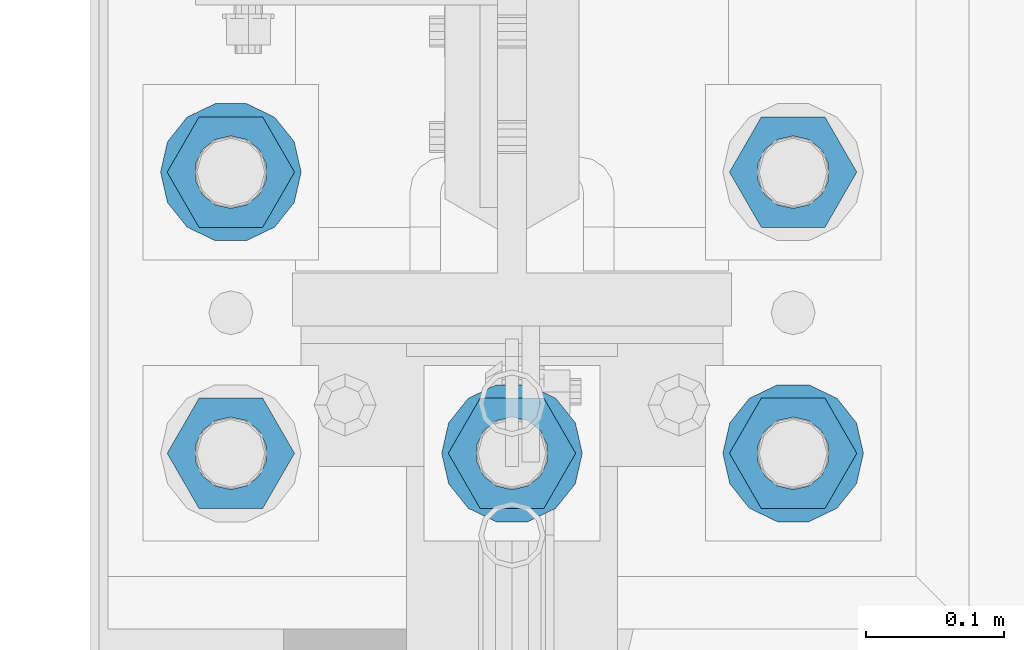
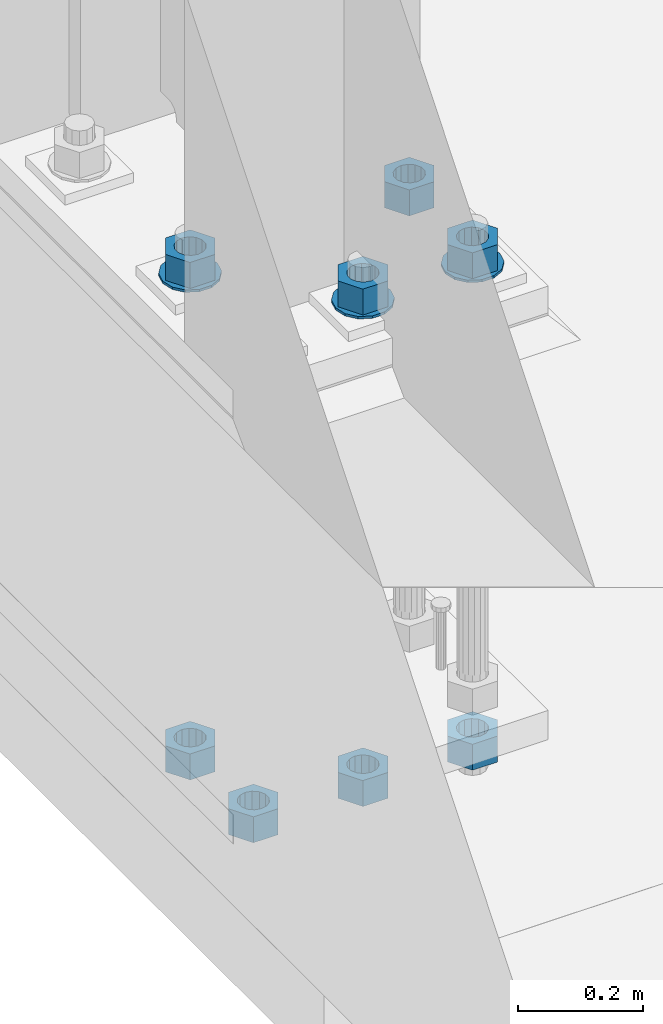
# One storey, part 846 of 1876: 11 columns, 1 element without a shape of its own.
"""IFC2X3 building model written with IfcOpenShell, lengths in millimetres."""

import ifcopenshell
import ifcopenshell.guid

model = None  # the IFC model being written
_history = None  # IfcOwnerHistory: only IFC2X3 demands one
_inside = {}  # id of a spatial element -> (the spatial element, [elements in it])
_under = {}  # id of a project, library or spatial element -> (it, [spatial elements below it])
_declared = {}  # id of a project -> (the project, [libraries it declares])
_typed = {}  # id of a type object -> (the type object, [elements of that type])
_made_of = {}  # id of a material, layer set ... -> (it, [elements and type objects made of it])


def new_model(schema):
    """Start an empty IFC model of exactly this schema.

    Asked for "IFC4X3", IfcOpenShell would pick the latest addendum, in which some entities
    have other attributes; the version numbers below select the first issue.
    IFC2X3 requires an IfcOwnerHistory on every rooted entity: one is made here for all.
    """
    global model, _history
    if schema == "IFC4X3":
        model = ifcopenshell.file(schema_version=(4, 3, 0, 0))
    else:
        model = ifcopenshell.file(schema=schema)
    _inside.clear()
    _under.clear()
    _declared.clear()
    _typed.clear()
    _made_of.clear()
    _history = None
    if model.schema == "IFC2X3":
        org = make("IfcOrganization", Name="unknown")
        user = make(
            "IfcPersonAndOrganization",
            ThePerson=make("IfcPerson", FamilyName="unknown"),
            TheOrganization=org,
        )
        app = make(
            "IfcApplication",
            ApplicationDeveloper=org,
            Version="unknown",
            ApplicationFullName="unknown",
            ApplicationIdentifier="unknown",
        )
        _history = make(
            "IfcOwnerHistory",
            OwningUser=user,
            OwningApplication=app,
            ChangeAction="ADDED",
            CreationDate=0,
        )
    return model


def make(cls, **values):
    """One entity of the class cls with the attributes given. An attribute that is None is left unset."""
    return model.create_entity(
        cls, **{name: value for name, value in values.items() if value is not None}
    )


def rooted(cls, **values):
    """An entity with a GlobalId (a new one), such as an element, a storey or a relation."""
    return make(cls, GlobalId=ifcopenshell.guid.new(), OwnerHistory=_history, **values)


def si_unit(unit_type, name, prefix=None):
    """IfcSIUnit, for example si_unit("LENGTHUNIT", "METRE", prefix="MILLI")."""
    return make("IfcSIUnit", UnitType=unit_type, Prefix=prefix, Name=name)


def assignment(units):
    """IfcUnitAssignment: the units of a project."""
    return None if units is None else make("IfcUnitAssignment", Units=units)


def point(xyz):
    """IfcCartesianPoint."""
    return None if xyz is None else make("IfcCartesianPoint", Coordinates=xyz)


def direction(xyz):
    """IfcDirection."""
    return None if xyz is None else make("IfcDirection", DirectionRatios=xyz)


def frame(location, z_axis=None, x_axis=None):
    """IfcAxis2Placement3D, a coordinate frame: its origin and axes. An axis left out is left unset."""
    return make(
        "IfcAxis2Placement3D",
        Location=point(location),
        Axis=direction(z_axis),
        RefDirection=direction(x_axis),
    )


def origin_with_axes():
    """The frame at (0, 0, 0) with the z axis (0, 0, 1) and the x axis (1, 0, 0) written out."""
    return frame((0.0, 0.0, 0.0), z_axis=(0.0, 0.0, 1.0), x_axis=(1.0, 0.0, 0.0))


def place(relative_to, where):
    """IfcLocalPlacement: puts the frame where relative to a parent placement (None: the world)."""
    return make(
        "IfcLocalPlacement", PlacementRelTo=relative_to, RelativePlacement=where
    )


def context(
    kind, dimensions, precision=None, world=None, true_north=None, identifier=None
):
    """IfcGeometricRepresentationContext, for example the 3D "Model" context."""
    return make(
        "IfcGeometricRepresentationContext",
        ContextIdentifier=identifier,
        ContextType=kind,
        CoordinateSpaceDimension=dimensions,
        Precision=precision,
        WorldCoordinateSystem=world,
        TrueNorth=true_north,
    )


def subcontext(parent, identifier, kind, view, scale=None):
    """IfcGeometricRepresentationSubContext, for example "Body" below "Model"."""
    return make(
        "IfcGeometricRepresentationSubContext",
        ContextIdentifier=identifier,
        ContextType=kind,
        ParentContext=parent,
        TargetScale=scale,
        TargetView=view,
    )


def project(units=None, contexts=None):
    """IfcProject with its units and contexts."""
    return rooted(
        "IfcProject",
        Name="project",
        RepresentationContexts=contexts,
        UnitsInContext=assignment(units),
    )


def spatial(cls, under=None, at=None, **own):
    """A site, building, storey or space (cls), placed at a placement, below another one or the project."""
    s = rooted(cls, ObjectPlacement=at, **own)
    if under is not None:
        _under.setdefault(under.id(), (under, []))[1].append(s)
    return s


def faces_of(points, faces, orient=None, outer=None):
    """IfcFace entities. A face is a list of loops; a loop is a list of indices into points, from 0.

    orient and outer hold one flag for each loop. By default every Orientation is true, the
    first loop of a face is its IfcFaceOuterBound and the others are IfcFaceBound.
    """
    made = []
    for i, loops in enumerate(faces):
        bounds = []
        for j, loop in enumerate(loops):
            is_outer = j == 0 if outer is None else outer[i][j]
            bounds.append(
                make(
                    "IfcFaceOuterBound" if is_outer else "IfcFaceBound",
                    Bound=make("IfcPolyLoop", Polygon=[points[k] for k in loop]),
                    Orientation=True if orient is None else orient[i][j],
                )
            )
        made.append(make("IfcFace", Bounds=bounds))
    return made


def faceted_brep(points, faces, orient=None, outer=None, voids=None):
    """IfcFacetedBrep: a solid bounded by flat faces; with voids (closed shells), ...WithVoids."""
    shared = [point(p) for p in points]
    hull = make("IfcClosedShell", CfsFaces=faces_of(shared, faces, orient, outer))
    if voids is None:
        return make("IfcFacetedBrep", Outer=hull)
    return make(
        "IfcFacetedBrepWithVoids",
        Outer=hull,
        Voids=[
            make(cls, CfsFaces=faces_of(shared, fs, o, b)) for cls, fs, o, b in voids
        ],
    )


def shape(context_of_items, identifier, shape_type, items):
    """IfcShapeRepresentation: the items that make up one representation, for example the "Body"."""
    return make(
        "IfcShapeRepresentation",
        ContextOfItems=context_of_items,
        RepresentationIdentifier=identifier,
        RepresentationType=shape_type,
        Items=items,
    )


def material(Name=None, Category=None):
    """IfcMaterial."""
    return make("IfcMaterial", Name=Name, Category=Category)


def made_of(thing, what):
    """Note that an element or type object is made of a material, layer set ...; save() writes the relation."""
    if what is not None:
        _made_of.setdefault(what.id(), (what, []))[1].append(thing)
    return thing


def type_object(cls, material=None, **own):
    """A type object (cls), such as IfcWallType, which elements share."""
    return made_of(rooted(cls, **own), material)


def element(
    cls,
    number,
    at=None,
    inside=None,
    cuts=None,
    type_object=None,
    material=None,
    context=None,
    identifier="Body",
    shape_type=None,
    held_by="IfcProductDefinitionShape",
    body=None,
    shapes=None,
    **own,
):
    """One element of the class cls, such as IfcWall. Its Tag is "e" and its number.

    at: its placement. inside: the storey or other place that contains it. cuts: it is an
    opening in that element (IfcRelVoidsElement). A single representation is given by context,
    identifier, shape_type and body (its items); several are given by shapes. held_by: the class
    of the entity that holds the representations. save() writes the other relations.
    """
    e = rooted(cls, Tag="e%d" % number, ObjectPlacement=at, **own)
    if body is not None:
        shapes = [shape(context, identifier, shape_type, body)]
    if shapes is not None:
        e.Representation = make(held_by, Representations=shapes)
    if inside is not None:
        _inside.setdefault(inside.id(), (inside, []))[1].append(e)
    if cuts is not None:
        rooted(
            "IfcRelVoidsElement", RelatingBuildingElement=cuts, RelatedOpeningElement=e
        )
    if type_object is not None:
        _typed.setdefault(type_object.id(), (type_object, []))[1].append(e)
    return made_of(e, material)


def aggregate(whole, parts):
    """IfcRelAggregates: a whole, such as a stair, and the parts it consists of."""
    return rooted("IfcRelAggregates", RelatingObject=whole, RelatedObjects=parts)


def save(model, path):
    """Write the relations noted so far, then the file.

    IfcRelAggregates (storeys below a building ...), IfcRelContainedInSpatialStructure (elements
    in a storey), IfcRelDefinesByType, IfcRelAssociatesMaterial and IfcRelDeclares: one each for
    every whole, place, type object, material and project.
    """
    for whole, parts in _under.values():
        aggregate(whole, parts)
    for where, things in _inside.values():
        rooted(
            "IfcRelContainedInSpatialStructure",
            RelatedElements=things,
            RelatingStructure=where,
        )
    for kind, things in _typed.values():
        rooted("IfcRelDefinesByType", RelatedObjects=things, RelatingType=kind)
    for what, things in _made_of.values():
        rooted("IfcRelAssociatesMaterial", RelatedObjects=things, RelatingMaterial=what)
    for by, libraries in _declared.values():
        rooted("IfcRelDeclares", RelatingContext=by, RelatedDefinitions=libraries)
    model.write(path)


model = new_model("IFC2X3")

# Units and contexts
model_context = context("Model", 3, precision=1e-05, world=origin_with_axes())
body_context = subcontext(model_context, "Body", "Model", "MODEL_VIEW")
ifc_project = project(units=[si_unit("LENGTHUNIT", "METRE", prefix="MILLI"), si_unit("AREAUNIT", "SQUARE_METRE"), si_unit("VOLUMEUNIT", "CUBIC_METRE"), si_unit("MASSUNIT", "GRAM", prefix="KILO"), si_unit("TIMEUNIT", "SECOND"), si_unit("PLANEANGLEUNIT", "RADIAN"), si_unit("SOLIDANGLEUNIT", "STERADIAN"), si_unit("THERMODYNAMICTEMPERATUREUNIT", "DEGREE_CELSIUS"), si_unit("LUMINOUSINTENSITYUNIT", "LUMEN")], contexts=[model_context])

# Site, building, storey
site_placement = place(None, origin_with_axes())
site = spatial("IfcSite", under=ifc_project, at=site_placement, CompositionType="ELEMENT")
building_placement = place(site_placement, origin_with_axes())
building = spatial("IfcBuilding", under=site, at=building_placement, Name="Undefined", CompositionType="ELEMENT")
storey_placement = place(building_placement, origin_with_axes())
storey = spatial("IfcBuildingStorey", under=building, at=storey_placement, Name="Undefined", CompositionType="ELEMENT", Elevation=0.0)

# Assembly, columns
assembly_placement = place(storey_placement, origin_with_axes())
assembly = element("IfcElementAssembly", 1, at=assembly_placement, inside=storey, Name="TEMPLATE", AssemblyPlace="NOTDEFINED", PredefinedType="RIGID_FRAME")
ifc_material_1 = material(Name="STEEL/F436")
column_type_1 = type_object("IfcColumnType", Name="2_WASHER", PredefinedType="NOTDEFINED")
column_1_placement = place(assembly_placement, frame((0.0, 7239.0, 119.0625), z_axis=(0.0, -1.0, 0.0), x_axis=(0.0, 0.0, -1.0)))
column_1 = element("IfcColumn", 2, at=column_1_placement, type_object=column_type_1, material=ifc_material_1, Name="WASHER", ObjectType="2_WASHER", context=body_context, shape_type="Brep", body=[
    faceted_brep([(0.0, -50.7999992370605, 9.09494701772928e-13), (0.0, -45.7692178020588, -22.0412936161442), (4.7625, -45.7692178020588, -22.0412936161442), (4.7625, -50.7999992370605, 9.09494701772928e-13), (0.0, -31.6732814587394, -39.7170387128856), (4.7625, -31.6732814587394, -39.7170387128856), (0.0, -11.3040632752118, -49.5263371950259), (4.7625, -11.3040632752118, -49.5263371950259), (0.0, 11.30406327521, -49.5263371950264), (4.7625, 11.30406327521, -49.5263371950264), (0.0, 31.6732814587385, -39.7170387128867), (4.7625, 31.6732814587385, -39.7170387128867), (0.0, 45.7692178020579, -22.041293616146), (4.7625, 45.7692178020579, -22.041293616146), (0.0, 50.7999992370605, -9.09494701772928e-13), (4.7625, 50.7999992370605, -9.09494701772928e-13), (0.0, 45.7692178020588, 22.0412936161442), (4.7625, 45.7692178020588, 22.0412936161442), (0.0, 31.6732814587394, 39.7170387128856), (4.7625, 31.6732814587394, 39.7170387128856), (0.0, 11.3040632752118, 49.5263371950259), (4.7625, 11.3040632752118, 49.5263371950259), (0.0, -11.30406327521, 49.5263371950264), (4.7625, -11.30406327521, 49.5263371950264), (0.0, -31.6732814587385, 39.7170387128867), (4.7625, -31.6732814587385, 39.7170387128867), (0.0, -45.7692178020579, 22.041293616146), (4.7625, -45.7692178020579, 22.041293616146), (0.0, 0.0, 26.9869995117188), (0.0, 11.7093983825444, 24.3146012721213), (4.7625, 11.7093983825444, 24.3146012721213), (4.7625, 0.0, 26.9869995117188), (0.0, 21.0996520289491, 16.8262864224157), (4.7625, 21.0996520289491, 16.8262864224157), (0.0, 26.3108629296712, 6.00524193584533), (4.7625, 26.3108629296712, 6.00524193584533), (0.0, 26.3108629296712, -6.00524193584533), (4.7625, 26.3108629296712, -6.00524193584533), (0.0, 21.0996520289491, -16.8262864224157), (4.7625, 21.0996520289491, -16.8262864224157), (0.0, 11.7093983825444, -24.3146012721213), (4.7625, 11.7093983825444, -24.3146012721213), (0.0, 0.0, -26.9869995117188), (4.7625, 0.0, -26.9869995117188), (0.0, -11.7093983825444, -24.3146012721213), (4.7625, -11.7093983825444, -24.3146012721213), (0.0, -21.0996520289491, -16.8262864224157), (4.7625, -21.0996520289491, -16.8262864224157), (0.0, -26.3108629296712, -6.00524193584533), (4.7625, -26.3108629296712, -6.00524193584533), (0.0, -26.3108629296712, 6.00524193584533), (4.7625, -26.3108629296712, 6.00524193584533), (0.0, -21.0996520289491, 16.8262864224157), (4.7625, -21.0996520289491, 16.8262864224157), (0.0, -11.7093983825444, 24.3146012721213), (4.7625, -11.7093983825444, 24.3146012721213)], [[[0, 1, 2, 3]], [[1, 4, 5, 2]], [[4, 6, 7, 5]], [[6, 8, 9, 7]], [[8, 10, 11, 9]], [[10, 12, 13, 11]], [[12, 14, 15, 13]], [[14, 16, 17, 15]], [[16, 18, 19, 17]], [[18, 20, 21, 19]], [[20, 22, 23, 21]], [[22, 24, 25, 23]], [[24, 26, 27, 25]], [[26, 0, 3, 27]], [[28, 29, 30, 31]], [[29, 32, 33, 30]], [[32, 34, 35, 33]], [[34, 36, 37, 35]], [[36, 38, 39, 37]], [[38, 40, 41, 39]], [[40, 42, 43, 41]], [[42, 44, 45, 43]], [[44, 46, 47, 45]], [[46, 48, 49, 47]], [[48, 50, 51, 49]], [[50, 52, 53, 51]], [[52, 54, 55, 53]], [[54, 28, 31, 55]], [[5, 7, 9, 11, 13, 15, 17, 19, 21, 23, 25, 27, 3, 2], [33, 35, 37, 39, 41, 43, 45, 47, 49, 51, 53, 55, 31, 30]], [[26, 24, 22, 20, 18, 16, 14, 12, 10, 8, 6, 4, 1, 0], [54, 52, 50, 48, 46, 44, 42, 40, 38, 36, 34, 32, 29, 28]]]),
])
column_2_placement = place(assembly_placement, frame((203.2, 7239.0, 119.0625), z_axis=(0.0, 1.0, 0.0), x_axis=(0.0, 0.0, -1.0)))
column_2 = element("IfcColumn", 3, at=column_2_placement, type_object=column_type_1, material=ifc_material_1, Name="WASHER", ObjectType="2_WASHER", context=body_context, shape_type="Brep", body=[
    faceted_brep([(0.0, -50.7999992370605, 9.09494701772928e-13), (0.0, -45.7692178020588, -22.0412936161442), (4.7625, -45.7692178020588, -22.0412936161442), (4.7625, -50.7999992370605, 9.09494701772928e-13), (0.0, -31.6732814587394, -39.7170387128856), (4.7625, -31.6732814587394, -39.7170387128856), (0.0, -11.3040632752118, -49.5263371950259), (4.7625, -11.3040632752118, -49.5263371950259), (0.0, 11.30406327521, -49.5263371950264), (4.7625, 11.30406327521, -49.5263371950264), (0.0, 31.6732814587385, -39.7170387128867), (4.7625, 31.6732814587385, -39.7170387128867), (0.0, 45.7692178020579, -22.041293616146), (4.7625, 45.7692178020579, -22.041293616146), (0.0, 50.7999992370605, -9.09494701772928e-13), (4.7625, 50.7999992370605, -9.09494701772928e-13), (0.0, 45.7692178020588, 22.0412936161442), (4.7625, 45.7692178020588, 22.0412936161442), (0.0, 31.6732814587394, 39.7170387128856), (4.7625, 31.6732814587394, 39.7170387128856), (0.0, 11.3040632752118, 49.5263371950259), (4.7625, 11.3040632752118, 49.5263371950259), (0.0, -11.30406327521, 49.5263371950264), (4.7625, -11.30406327521, 49.5263371950264), (0.0, -31.6732814587385, 39.7170387128867), (4.7625, -31.6732814587385, 39.7170387128867), (0.0, -45.7692178020579, 22.041293616146), (4.7625, -45.7692178020579, 22.041293616146), (0.0, 0.0, 26.9869995117188), (0.0, 11.7093983825444, 24.3146012721213), (4.7625, 11.7093983825444, 24.3146012721213), (4.7625, 0.0, 26.9869995117188), (0.0, 21.0996520289491, 16.8262864224157), (4.7625, 21.0996520289491, 16.8262864224157), (0.0, 26.3108629296712, 6.00524193584533), (4.7625, 26.3108629296712, 6.00524193584533), (0.0, 26.3108629296712, -6.00524193584533), (4.7625, 26.3108629296712, -6.00524193584533), (0.0, 21.0996520289491, -16.8262864224157), (4.7625, 21.0996520289491, -16.8262864224157), (0.0, 11.7093983825444, -24.3146012721213), (4.7625, 11.7093983825444, -24.3146012721213), (0.0, 0.0, -26.9869995117188), (4.7625, 0.0, -26.9869995117188), (0.0, -11.7093983825444, -24.3146012721213), (4.7625, -11.7093983825444, -24.3146012721213), (0.0, -21.0996520289491, -16.8262864224157), (4.7625, -21.0996520289491, -16.8262864224157), (0.0, -26.3108629296712, -6.00524193584533), (4.7625, -26.3108629296712, -6.00524193584533), (0.0, -26.3108629296712, 6.00524193584533), (4.7625, -26.3108629296712, 6.00524193584533), (0.0, -21.0996520289491, 16.8262864224157), (4.7625, -21.0996520289491, 16.8262864224157), (0.0, -11.7093983825444, 24.3146012721213), (4.7625, -11.7093983825444, 24.3146012721213)], [[[0, 1, 2, 3]], [[1, 4, 5, 2]], [[4, 6, 7, 5]], [[6, 8, 9, 7]], [[8, 10, 11, 9]], [[10, 12, 13, 11]], [[12, 14, 15, 13]], [[14, 16, 17, 15]], [[16, 18, 19, 17]], [[18, 20, 21, 19]], [[20, 22, 23, 21]], [[22, 24, 25, 23]], [[24, 26, 27, 25]], [[26, 0, 3, 27]], [[28, 29, 30, 31]], [[29, 32, 33, 30]], [[32, 34, 35, 33]], [[34, 36, 37, 35]], [[36, 38, 39, 37]], [[38, 40, 41, 39]], [[40, 42, 43, 41]], [[42, 44, 45, 43]], [[44, 46, 47, 45]], [[46, 48, 49, 47]], [[48, 50, 51, 49]], [[50, 52, 53, 51]], [[52, 54, 55, 53]], [[54, 28, 31, 55]], [[5, 7, 9, 11, 13, 15, 17, 19, 21, 23, 25, 27, 3, 2], [33, 35, 37, 39, 41, 43, 45, 47, 49, 51, 53, 55, 31, 30]], [[26, 24, 22, 20, 18, 16, 14, 12, 10, 8, 6, 4, 1, 0], [54, 52, 50, 48, 46, 44, 42, 40, 38, 36, 34, 32, 29, 28]]]),
])
column_3_placement = place(assembly_placement, frame((-203.2, 7442.2, 119.0625), z_axis=(0.0, -1.0, 0.0), x_axis=(0.0, 0.0, -1.0)))
column_3 = element("IfcColumn", 4, at=column_3_placement, type_object=column_type_1, material=ifc_material_1, Name="WASHER", ObjectType="2_WASHER", context=body_context, shape_type="Brep", body=[
    faceted_brep([(0.0, -50.7999992370605, 9.09494701772928e-13), (0.0, -45.7692178020588, -22.0412936161442), (4.7625, -45.7692178020588, -22.0412936161442), (4.7625, -50.7999992370605, 9.09494701772928e-13), (0.0, -31.6732814587394, -39.7170387128856), (4.7625, -31.6732814587394, -39.7170387128856), (0.0, -11.3040632752118, -49.5263371950259), (4.7625, -11.3040632752118, -49.5263371950259), (0.0, 11.30406327521, -49.5263371950264), (4.7625, 11.30406327521, -49.5263371950264), (0.0, 31.6732814587385, -39.7170387128867), (4.7625, 31.6732814587385, -39.7170387128867), (0.0, 45.7692178020579, -22.041293616146), (4.7625, 45.7692178020579, -22.041293616146), (0.0, 50.7999992370605, -9.09494701772928e-13), (4.7625, 50.7999992370605, -9.09494701772928e-13), (0.0, 45.7692178020588, 22.0412936161442), (4.7625, 45.7692178020588, 22.0412936161442), (0.0, 31.6732814587394, 39.7170387128856), (4.7625, 31.6732814587394, 39.7170387128856), (0.0, 11.3040632752118, 49.5263371950259), (4.7625, 11.3040632752118, 49.5263371950259), (0.0, -11.30406327521, 49.5263371950264), (4.7625, -11.30406327521, 49.5263371950264), (0.0, -31.6732814587385, 39.7170387128867), (4.7625, -31.6732814587385, 39.7170387128867), (0.0, -45.7692178020579, 22.041293616146), (4.7625, -45.7692178020579, 22.041293616146), (0.0, 0.0, 26.9869995117188), (0.0, 11.7093983825444, 24.3146012721213), (4.7625, 11.7093983825444, 24.3146012721213), (4.7625, 0.0, 26.9869995117188), (0.0, 21.0996520289491, 16.8262864224157), (4.7625, 21.0996520289491, 16.8262864224157), (0.0, 26.3108629296712, 6.00524193584533), (4.7625, 26.3108629296712, 6.00524193584533), (0.0, 26.3108629296712, -6.00524193584533), (4.7625, 26.3108629296712, -6.00524193584533), (0.0, 21.0996520289491, -16.8262864224157), (4.7625, 21.0996520289491, -16.8262864224157), (0.0, 11.7093983825444, -24.3146012721213), (4.7625, 11.7093983825444, -24.3146012721213), (0.0, 0.0, -26.9869995117188), (4.7625, 0.0, -26.9869995117188), (0.0, -11.7093983825444, -24.3146012721213), (4.7625, -11.7093983825444, -24.3146012721213), (0.0, -21.0996520289491, -16.8262864224157), (4.7625, -21.0996520289491, -16.8262864224157), (0.0, -26.3108629296712, -6.00524193584533), (4.7625, -26.3108629296712, -6.00524193584533), (0.0, -26.3108629296712, 6.00524193584533), (4.7625, -26.3108629296712, 6.00524193584533), (0.0, -21.0996520289491, 16.8262864224157), (4.7625, -21.0996520289491, 16.8262864224157), (0.0, -11.7093983825444, 24.3146012721213), (4.7625, -11.7093983825444, 24.3146012721213)], [[[0, 1, 2, 3]], [[1, 4, 5, 2]], [[4, 6, 7, 5]], [[6, 8, 9, 7]], [[8, 10, 11, 9]], [[10, 12, 13, 11]], [[12, 14, 15, 13]], [[14, 16, 17, 15]], [[16, 18, 19, 17]], [[18, 20, 21, 19]], [[20, 22, 23, 21]], [[22, 24, 25, 23]], [[24, 26, 27, 25]], [[26, 0, 3, 27]], [[28, 29, 30, 31]], [[29, 32, 33, 30]], [[32, 34, 35, 33]], [[34, 36, 37, 35]], [[36, 38, 39, 37]], [[38, 40, 41, 39]], [[40, 42, 43, 41]], [[42, 44, 45, 43]], [[44, 46, 47, 45]], [[46, 48, 49, 47]], [[48, 50, 51, 49]], [[50, 52, 53, 51]], [[52, 54, 55, 53]], [[54, 28, 31, 55]], [[5, 7, 9, 11, 13, 15, 17, 19, 21, 23, 25, 27, 3, 2], [33, 35, 37, 39, 41, 43, 45, 47, 49, 51, 53, 55, 31, 30]], [[26, 24, 22, 20, 18, 16, 14, 12, 10, 8, 6, 4, 1, 0], [54, 52, 50, 48, 46, 44, 42, 40, 38, 36, 34, 32, 29, 28]]]),
])
ifc_material_2 = material(Name="STEEL/A563")
column_type_2 = type_object("IfcColumnType", Name="2_HEAVY_HEX_NUT", PredefinedType="NOTDEFINED")
column_4_placement = place(assembly_placement, frame((-203.2, 7239.0, -793.75), z_axis=(0.0, -1.0, 0.0), x_axis=(0.0, 0.0, -1.0)))
column_4 = element("IfcColumn", 5, at=column_4_placement, type_object=column_type_2, material=ifc_material_2, Name="NUT", ObjectType="2_HEAVY_HEX_NUT", context=body_context, shape_type="Brep", body=[
    faceted_brep([(0.0, -46.0369987487793, 9.09494701772928e-13), (0.0, -23.0184993743896, -39.869213104248), (50.8, -23.0184993743896, -39.869213104248), (50.8, -46.0369987487793, 9.09494701772928e-13), (0.0, 23.0184993743896, -39.869213104248), (50.8, 23.0184993743896, -39.869213104248), (0.0, 46.0369987487793, -9.09494701772928e-13), (50.8, 46.0369987487793, -9.09494701772928e-13), (0.0, 23.0184993743896, 39.869213104248), (50.8, 23.0184993743896, 39.869213104248), (0.0, -23.0184993743896, 39.869213104248), (50.8, -23.0184993743896, 39.869213104248), (0.0, 0.0, 26.1940002441406), (0.0, 11.3650617044514, 23.5999013092769), (50.8, 11.3650617044513, 23.5999013092771), (50.8, 0.0, 26.1940002441406), (0.0, 20.4791109456437, 16.3316083006703), (50.8, 20.4791109456439, 16.3316083006703), (0.0, 25.5370200498346, 5.82867859874477), (50.8, 25.5370200498343, 5.82867859874455), (0.0, 25.5370200498346, -5.82867859874477), (50.8, 25.5370200498343, -5.82867859874455), (0.0, 20.4791109456437, -16.3316083006703), (50.8, 20.4791109456439, -16.3316083006703), (0.0, 11.3650617044514, -23.5999013092769), (50.8, 11.3650617044514, -23.5999013092771), (0.0, 0.0, -26.1940002441406), (50.8, 0.0, -26.1940002441406), (0.0, -11.3650617044514, -23.5999013092769), (50.8, -11.3650617044513, -23.5999013092771), (0.0, -20.4791109456437, -16.3316083006703), (50.8, -20.4791109456439, -16.3316083006703), (0.0, -25.5370200498346, -5.82867859874477), (50.8, -25.5370200498343, -5.82867859874455), (0.0, -25.5370200498346, 5.82867859874477), (50.8, -25.5370200498343, 5.82867859874455), (0.0, -20.4791109456437, 16.3316083006703), (50.8, -20.4791109456439, 16.3316083006703), (0.0, -11.3650617044514, 23.5999013092769), (50.8, -11.3650617044514, 23.5999013092771)], [[[0, 1, 2, 3]], [[1, 4, 5, 2]], [[4, 6, 7, 5]], [[6, 8, 9, 7]], [[8, 10, 11, 9]], [[10, 0, 3, 11]], [[12, 13, 14, 15]], [[13, 16, 17, 14]], [[16, 18, 19, 17]], [[18, 20, 21, 19]], [[20, 22, 23, 21]], [[22, 24, 25, 23]], [[24, 26, 27, 25]], [[26, 28, 29, 27]], [[28, 30, 31, 29]], [[30, 32, 33, 31]], [[32, 34, 35, 33]], [[34, 36, 37, 35]], [[36, 38, 39, 37]], [[38, 12, 15, 39]], [[5, 7, 9, 11, 3, 2], [17, 19, 21, 23, 25, 27, 29, 31, 33, 35, 37, 39, 15, 14]], [[10, 8, 6, 4, 1, 0], [38, 36, 34, 32, 30, 28, 26, 24, 22, 20, 18, 16, 13, 12]]]),
])
column_5_placement = place(assembly_placement, frame((0.0, 7239.0, 169.8625), z_axis=(0.0, -1.0, 0.0), x_axis=(0.0, 0.0, -1.0)))
column_5 = element("IfcColumn", 6, at=column_5_placement, type_object=column_type_2, material=ifc_material_2, Name="NUT", ObjectType="2_HEAVY_HEX_NUT", context=body_context, shape_type="Brep", body=[
    faceted_brep([(0.0, -46.0369987487793, 9.09494701772928e-13), (0.0, -23.0184993743896, -39.869213104248), (50.8, -23.0184993743896, -39.869213104248), (50.8, -46.0369987487793, 9.09494701772928e-13), (0.0, 23.0184993743896, -39.869213104248), (50.8, 23.0184993743896, -39.869213104248), (0.0, 46.0369987487793, -9.09494701772928e-13), (50.8, 46.0369987487793, -9.09494701772928e-13), (0.0, 23.0184993743896, 39.869213104248), (50.8, 23.0184993743896, 39.869213104248), (0.0, -23.0184993743896, 39.869213104248), (50.8, -23.0184993743896, 39.869213104248), (0.0, 0.0, 26.1940002441406), (0.0, 11.3650617044514, 23.5999013092769), (50.8, 11.3650617044513, 23.5999013092771), (50.8, 0.0, 26.1940002441406), (0.0, 20.4791109456437, 16.3316083006703), (50.8, 20.4791109456439, 16.3316083006703), (0.0, 25.5370200498346, 5.82867859874477), (50.8, 25.5370200498343, 5.82867859874455), (0.0, 25.5370200498346, -5.82867859874477), (50.8, 25.5370200498343, -5.82867859874455), (0.0, 20.4791109456437, -16.3316083006703), (50.8, 20.4791109456439, -16.3316083006703), (0.0, 11.3650617044514, -23.5999013092769), (50.8, 11.3650617044514, -23.5999013092771), (0.0, 0.0, -26.1940002441406), (50.8, 0.0, -26.1940002441406), (0.0, -11.3650617044514, -23.5999013092769), (50.8, -11.3650617044513, -23.5999013092771), (0.0, -20.4791109456437, -16.3316083006703), (50.8, -20.4791109456439, -16.3316083006703), (0.0, -25.5370200498346, -5.82867859874477), (50.8, -25.5370200498343, -5.82867859874455), (0.0, -25.5370200498346, 5.82867859874477), (50.8, -25.5370200498343, 5.82867859874455), (0.0, -20.4791109456437, 16.3316083006703), (50.8, -20.4791109456439, 16.3316083006703), (0.0, -11.3650617044514, 23.5999013092769), (50.8, -11.3650617044514, 23.5999013092771)], [[[0, 1, 2, 3]], [[1, 4, 5, 2]], [[4, 6, 7, 5]], [[6, 8, 9, 7]], [[8, 10, 11, 9]], [[10, 0, 3, 11]], [[12, 13, 14, 15]], [[13, 16, 17, 14]], [[16, 18, 19, 17]], [[18, 20, 21, 19]], [[20, 22, 23, 21]], [[22, 24, 25, 23]], [[24, 26, 27, 25]], [[26, 28, 29, 27]], [[28, 30, 31, 29]], [[30, 32, 33, 31]], [[32, 34, 35, 33]], [[34, 36, 37, 35]], [[36, 38, 39, 37]], [[38, 12, 15, 39]], [[5, 7, 9, 11, 3, 2], [17, 19, 21, 23, 25, 27, 29, 31, 33, 35, 37, 39, 15, 14]], [[10, 8, 6, 4, 1, 0], [38, 36, 34, 32, 30, 28, 26, 24, 22, 20, 18, 16, 13, 12]]]),
])
column_6_placement = place(assembly_placement, frame((0.0, 7239.0, -793.75), z_axis=(0.0, -1.0, 0.0), x_axis=(0.0, 0.0, -1.0)))
column_6 = element("IfcColumn", 7, at=column_6_placement, type_object=column_type_2, material=ifc_material_2, Name="NUT", ObjectType="2_HEAVY_HEX_NUT", context=body_context, shape_type="Brep", body=[
    faceted_brep([(0.0, -46.0369987487793, 9.09494701772928e-13), (0.0, -23.0184993743896, -39.869213104248), (50.8, -23.0184993743896, -39.869213104248), (50.8, -46.0369987487793, 9.09494701772928e-13), (0.0, 23.0184993743896, -39.869213104248), (50.8, 23.0184993743896, -39.869213104248), (0.0, 46.0369987487793, -9.09494701772928e-13), (50.8, 46.0369987487793, -9.09494701772928e-13), (0.0, 23.0184993743896, 39.869213104248), (50.8, 23.0184993743896, 39.869213104248), (0.0, -23.0184993743896, 39.869213104248), (50.8, -23.0184993743896, 39.869213104248), (0.0, 0.0, 26.1940002441406), (0.0, 11.3650617044514, 23.5999013092769), (50.8, 11.3650617044513, 23.5999013092771), (50.8, 0.0, 26.1940002441406), (0.0, 20.4791109456437, 16.3316083006703), (50.8, 20.4791109456439, 16.3316083006703), (0.0, 25.5370200498346, 5.82867859874477), (50.8, 25.5370200498343, 5.82867859874455), (0.0, 25.5370200498346, -5.82867859874477), (50.8, 25.5370200498343, -5.82867859874455), (0.0, 20.4791109456437, -16.3316083006703), (50.8, 20.4791109456439, -16.3316083006703), (0.0, 11.3650617044514, -23.5999013092769), (50.8, 11.3650617044514, -23.5999013092771), (0.0, 0.0, -26.1940002441406), (50.8, 0.0, -26.1940002441406), (0.0, -11.3650617044514, -23.5999013092769), (50.8, -11.3650617044513, -23.5999013092771), (0.0, -20.4791109456437, -16.3316083006703), (50.8, -20.4791109456439, -16.3316083006703), (0.0, -25.5370200498346, -5.82867859874477), (50.8, -25.5370200498343, -5.82867859874455), (0.0, -25.5370200498346, 5.82867859874477), (50.8, -25.5370200498343, 5.82867859874455), (0.0, -20.4791109456437, 16.3316083006703), (50.8, -20.4791109456439, 16.3316083006703), (0.0, -11.3650617044514, 23.5999013092769), (50.8, -11.3650617044514, 23.5999013092771)], [[[0, 1, 2, 3]], [[1, 4, 5, 2]], [[4, 6, 7, 5]], [[6, 8, 9, 7]], [[8, 10, 11, 9]], [[10, 0, 3, 11]], [[12, 13, 14, 15]], [[13, 16, 17, 14]], [[16, 18, 19, 17]], [[18, 20, 21, 19]], [[20, 22, 23, 21]], [[22, 24, 25, 23]], [[24, 26, 27, 25]], [[26, 28, 29, 27]], [[28, 30, 31, 29]], [[30, 32, 33, 31]], [[32, 34, 35, 33]], [[34, 36, 37, 35]], [[36, 38, 39, 37]], [[38, 12, 15, 39]], [[5, 7, 9, 11, 3, 2], [17, 19, 21, 23, 25, 27, 29, 31, 33, 35, 37, 39, 15, 14]], [[10, 8, 6, 4, 1, 0], [38, 36, 34, 32, 30, 28, 26, 24, 22, 20, 18, 16, 13, 12]]]),
])
column_7_placement = place(assembly_placement, frame((203.2, 7239.0, 169.8625), z_axis=(0.0, 1.0, 0.0), x_axis=(0.0, 0.0, -1.0)))
column_7 = element("IfcColumn", 8, at=column_7_placement, type_object=column_type_2, material=ifc_material_2, Name="NUT", ObjectType="2_HEAVY_HEX_NUT", context=body_context, shape_type="Brep", body=[
    faceted_brep([(0.0, -46.0369987487793, 9.09494701772928e-13), (0.0, -23.0184993743896, -39.869213104248), (50.8, -23.0184993743896, -39.869213104248), (50.8, -46.0369987487793, 9.09494701772928e-13), (0.0, 23.0184993743896, -39.869213104248), (50.8, 23.0184993743896, -39.869213104248), (0.0, 46.0369987487793, -9.09494701772928e-13), (50.8, 46.0369987487793, -9.09494701772928e-13), (0.0, 23.0184993743896, 39.869213104248), (50.8, 23.0184993743896, 39.869213104248), (0.0, -23.0184993743896, 39.869213104248), (50.8, -23.0184993743896, 39.869213104248), (0.0, 0.0, 26.1940002441406), (0.0, 11.3650617044514, 23.5999013092769), (50.8, 11.3650617044513, 23.5999013092771), (50.8, 0.0, 26.1940002441406), (0.0, 20.4791109456437, 16.3316083006703), (50.8, 20.4791109456439, 16.3316083006703), (0.0, 25.5370200498346, 5.82867859874477), (50.8, 25.5370200498343, 5.82867859874455), (0.0, 25.5370200498346, -5.82867859874477), (50.8, 25.5370200498343, -5.82867859874455), (0.0, 20.4791109456437, -16.3316083006703), (50.8, 20.4791109456439, -16.3316083006703), (0.0, 11.3650617044514, -23.5999013092769), (50.8, 11.3650617044514, -23.5999013092771), (0.0, 0.0, -26.1940002441406), (50.8, 0.0, -26.1940002441406), (0.0, -11.3650617044514, -23.5999013092769), (50.8, -11.3650617044513, -23.5999013092771), (0.0, -20.4791109456437, -16.3316083006703), (50.8, -20.4791109456439, -16.3316083006703), (0.0, -25.5370200498346, -5.82867859874477), (50.8, -25.5370200498343, -5.82867859874455), (0.0, -25.5370200498346, 5.82867859874477), (50.8, -25.5370200498343, 5.82867859874455), (0.0, -20.4791109456437, 16.3316083006703), (50.8, -20.4791109456439, 16.3316083006703), (0.0, -11.3650617044514, 23.5999013092769), (50.8, -11.3650617044514, 23.5999013092771)], [[[0, 1, 2, 3]], [[1, 4, 5, 2]], [[4, 6, 7, 5]], [[6, 8, 9, 7]], [[8, 10, 11, 9]], [[10, 0, 3, 11]], [[12, 13, 14, 15]], [[13, 16, 17, 14]], [[16, 18, 19, 17]], [[18, 20, 21, 19]], [[20, 22, 23, 21]], [[22, 24, 25, 23]], [[24, 26, 27, 25]], [[26, 28, 29, 27]], [[28, 30, 31, 29]], [[30, 32, 33, 31]], [[32, 34, 35, 33]], [[34, 36, 37, 35]], [[36, 38, 39, 37]], [[38, 12, 15, 39]], [[5, 7, 9, 11, 3, 2], [17, 19, 21, 23, 25, 27, 29, 31, 33, 35, 37, 39, 15, 14]], [[10, 8, 6, 4, 1, 0], [38, 36, 34, 32, 30, 28, 26, 24, 22, 20, 18, 16, 13, 12]]]),
])
column_8_placement = place(assembly_placement, frame((203.2, 7239.0, -793.75), z_axis=(0.0, 1.0, 0.0), x_axis=(0.0, 0.0, -1.0)))
column_8 = element("IfcColumn", 9, at=column_8_placement, type_object=column_type_2, material=ifc_material_2, Name="NUT", ObjectType="2_HEAVY_HEX_NUT", context=body_context, shape_type="Brep", body=[
    faceted_brep([(0.0, -46.0369987487793, 9.09494701772928e-13), (0.0, -23.0184993743896, -39.869213104248), (50.8, -23.0184993743896, -39.869213104248), (50.8, -46.0369987487793, 9.09494701772928e-13), (0.0, 23.0184993743896, -39.869213104248), (50.8, 23.0184993743896, -39.869213104248), (0.0, 46.0369987487793, -9.09494701772928e-13), (50.8, 46.0369987487793, -9.09494701772928e-13), (0.0, 23.0184993743896, 39.869213104248), (50.8, 23.0184993743896, 39.869213104248), (0.0, -23.0184993743896, 39.869213104248), (50.8, -23.0184993743896, 39.869213104248), (0.0, 0.0, 26.1940002441406), (0.0, 11.3650617044514, 23.5999013092769), (50.8, 11.3650617044513, 23.5999013092771), (50.8, 0.0, 26.1940002441406), (0.0, 20.4791109456437, 16.3316083006703), (50.8, 20.4791109456439, 16.3316083006703), (0.0, 25.5370200498346, 5.82867859874477), (50.8, 25.5370200498343, 5.82867859874455), (0.0, 25.5370200498346, -5.82867859874477), (50.8, 25.5370200498343, -5.82867859874455), (0.0, 20.4791109456437, -16.3316083006703), (50.8, 20.4791109456439, -16.3316083006703), (0.0, 11.3650617044514, -23.5999013092769), (50.8, 11.3650617044514, -23.5999013092771), (0.0, 0.0, -26.1940002441406), (50.8, 0.0, -26.1940002441406), (0.0, -11.3650617044514, -23.5999013092769), (50.8, -11.3650617044513, -23.5999013092771), (0.0, -20.4791109456437, -16.3316083006703), (50.8, -20.4791109456439, -16.3316083006703), (0.0, -25.5370200498346, -5.82867859874477), (50.8, -25.5370200498343, -5.82867859874455), (0.0, -25.5370200498346, 5.82867859874477), (50.8, -25.5370200498343, 5.82867859874455), (0.0, -20.4791109456437, 16.3316083006703), (50.8, -20.4791109456439, 16.3316083006703), (0.0, -11.3650617044514, 23.5999013092769), (50.8, -11.3650617044514, 23.5999013092771)], [[[0, 1, 2, 3]], [[1, 4, 5, 2]], [[4, 6, 7, 5]], [[6, 8, 9, 7]], [[8, 10, 11, 9]], [[10, 0, 3, 11]], [[12, 13, 14, 15]], [[13, 16, 17, 14]], [[16, 18, 19, 17]], [[18, 20, 21, 19]], [[20, 22, 23, 21]], [[22, 24, 25, 23]], [[24, 26, 27, 25]], [[26, 28, 29, 27]], [[28, 30, 31, 29]], [[30, 32, 33, 31]], [[32, 34, 35, 33]], [[34, 36, 37, 35]], [[36, 38, 39, 37]], [[38, 12, 15, 39]], [[5, 7, 9, 11, 3, 2], [17, 19, 21, 23, 25, 27, 29, 31, 33, 35, 37, 39, 15, 14]], [[10, 8, 6, 4, 1, 0], [38, 36, 34, 32, 30, 28, 26, 24, 22, 20, 18, 16, 13, 12]]]),
])
column_9_placement = place(assembly_placement, frame((-203.2, 7442.2, 169.8625), z_axis=(0.0, -1.0, 0.0), x_axis=(0.0, 0.0, -1.0)))
column_9 = element("IfcColumn", 10, at=column_9_placement, type_object=column_type_2, material=ifc_material_2, Name="NUT", ObjectType="2_HEAVY_HEX_NUT", context=body_context, shape_type="Brep", body=[
    faceted_brep([(0.0, -46.0369987487793, 9.09494701772928e-13), (0.0, -23.0184993743896, -39.869213104248), (50.8, -23.0184993743896, -39.869213104248), (50.8, -46.0369987487793, 9.09494701772928e-13), (0.0, 23.0184993743896, -39.869213104248), (50.8, 23.0184993743896, -39.869213104248), (0.0, 46.0369987487793, -9.09494701772928e-13), (50.8, 46.0369987487793, -9.09494701772928e-13), (0.0, 23.0184993743896, 39.869213104248), (50.8, 23.0184993743896, 39.869213104248), (0.0, -23.0184993743896, 39.869213104248), (50.8, -23.0184993743896, 39.869213104248), (0.0, 0.0, 26.1940002441406), (0.0, 11.3650617044514, 23.5999013092769), (50.8, 11.3650617044513, 23.5999013092771), (50.8, 0.0, 26.1940002441406), (0.0, 20.4791109456437, 16.3316083006703), (50.8, 20.4791109456439, 16.3316083006703), (0.0, 25.5370200498346, 5.82867859874477), (50.8, 25.5370200498343, 5.82867859874455), (0.0, 25.5370200498346, -5.82867859874477), (50.8, 25.5370200498343, -5.82867859874455), (0.0, 20.4791109456437, -16.3316083006703), (50.8, 20.4791109456439, -16.3316083006703), (0.0, 11.3650617044514, -23.5999013092769), (50.8, 11.3650617044514, -23.5999013092771), (0.0, 0.0, -26.1940002441406), (50.8, 0.0, -26.1940002441406), (0.0, -11.3650617044514, -23.5999013092769), (50.8, -11.3650617044513, -23.5999013092771), (0.0, -20.4791109456437, -16.3316083006703), (50.8, -20.4791109456439, -16.3316083006703), (0.0, -25.5370200498346, -5.82867859874477), (50.8, -25.5370200498343, -5.82867859874455), (0.0, -25.5370200498346, 5.82867859874477), (50.8, -25.5370200498343, 5.82867859874455), (0.0, -20.4791109456437, 16.3316083006703), (50.8, -20.4791109456439, 16.3316083006703), (0.0, -11.3650617044514, 23.5999013092769), (50.8, -11.3650617044514, 23.5999013092771)], [[[0, 1, 2, 3]], [[1, 4, 5, 2]], [[4, 6, 7, 5]], [[6, 8, 9, 7]], [[8, 10, 11, 9]], [[10, 0, 3, 11]], [[12, 13, 14, 15]], [[13, 16, 17, 14]], [[16, 18, 19, 17]], [[18, 20, 21, 19]], [[20, 22, 23, 21]], [[22, 24, 25, 23]], [[24, 26, 27, 25]], [[26, 28, 29, 27]], [[28, 30, 31, 29]], [[30, 32, 33, 31]], [[32, 34, 35, 33]], [[34, 36, 37, 35]], [[36, 38, 39, 37]], [[38, 12, 15, 39]], [[5, 7, 9, 11, 3, 2], [17, 19, 21, 23, 25, 27, 29, 31, 33, 35, 37, 39, 15, 14]], [[10, 8, 6, 4, 1, 0], [38, 36, 34, 32, 30, 28, 26, 24, 22, 20, 18, 16, 13, 12]]]),
])
column_10_placement = place(assembly_placement, frame((-203.2, 7442.2, -793.75), z_axis=(0.0, -1.0, 0.0), x_axis=(0.0, 0.0, -1.0)))
column_10 = element("IfcColumn", 11, at=column_10_placement, type_object=column_type_2, material=ifc_material_2, Name="NUT", ObjectType="2_HEAVY_HEX_NUT", context=body_context, shape_type="Brep", body=[
    faceted_brep([(0.0, -46.0369987487793, 9.09494701772928e-13), (0.0, -23.0184993743896, -39.869213104248), (50.8, -23.0184993743896, -39.869213104248), (50.8, -46.0369987487793, 9.09494701772928e-13), (0.0, 23.0184993743896, -39.869213104248), (50.8, 23.0184993743896, -39.869213104248), (0.0, 46.0369987487793, -9.09494701772928e-13), (50.8, 46.0369987487793, -9.09494701772928e-13), (0.0, 23.0184993743896, 39.869213104248), (50.8, 23.0184993743896, 39.869213104248), (0.0, -23.0184993743896, 39.869213104248), (50.8, -23.0184993743896, 39.869213104248), (0.0, 0.0, 26.1940002441406), (0.0, 11.3650617044514, 23.5999013092769), (50.8, 11.3650617044513, 23.5999013092771), (50.8, 0.0, 26.1940002441406), (0.0, 20.4791109456437, 16.3316083006703), (50.8, 20.4791109456439, 16.3316083006703), (0.0, 25.5370200498346, 5.82867859874477), (50.8, 25.5370200498343, 5.82867859874455), (0.0, 25.5370200498346, -5.82867859874477), (50.8, 25.5370200498343, -5.82867859874455), (0.0, 20.4791109456437, -16.3316083006703), (50.8, 20.4791109456439, -16.3316083006703), (0.0, 11.3650617044514, -23.5999013092769), (50.8, 11.3650617044514, -23.5999013092771), (0.0, 0.0, -26.1940002441406), (50.8, 0.0, -26.1940002441406), (0.0, -11.3650617044514, -23.5999013092769), (50.8, -11.3650617044513, -23.5999013092771), (0.0, -20.4791109456437, -16.3316083006703), (50.8, -20.4791109456439, -16.3316083006703), (0.0, -25.5370200498346, -5.82867859874477), (50.8, -25.5370200498343, -5.82867859874455), (0.0, -25.5370200498346, 5.82867859874477), (50.8, -25.5370200498343, 5.82867859874455), (0.0, -20.4791109456437, 16.3316083006703), (50.8, -20.4791109456439, 16.3316083006703), (0.0, -11.3650617044514, 23.5999013092769), (50.8, -11.3650617044514, 23.5999013092771)], [[[0, 1, 2, 3]], [[1, 4, 5, 2]], [[4, 6, 7, 5]], [[6, 8, 9, 7]], [[8, 10, 11, 9]], [[10, 0, 3, 11]], [[12, 13, 14, 15]], [[13, 16, 17, 14]], [[16, 18, 19, 17]], [[18, 20, 21, 19]], [[20, 22, 23, 21]], [[22, 24, 25, 23]], [[24, 26, 27, 25]], [[26, 28, 29, 27]], [[28, 30, 31, 29]], [[30, 32, 33, 31]], [[32, 34, 35, 33]], [[34, 36, 37, 35]], [[36, 38, 39, 37]], [[38, 12, 15, 39]], [[5, 7, 9, 11, 3, 2], [17, 19, 21, 23, 25, 27, 29, 31, 33, 35, 37, 39, 15, 14]], [[10, 8, 6, 4, 1, 0], [38, 36, 34, 32, 30, 28, 26, 24, 22, 20, 18, 16, 13, 12]]]),
])
column_11_placement = place(assembly_placement, frame((203.2, 7442.2, 169.8625), z_axis=(0.0, 1.0, 0.0), x_axis=(0.0, 0.0, -1.0)))
column_11 = element("IfcColumn", 12, at=column_11_placement, type_object=column_type_2, material=ifc_material_2, Name="NUT", ObjectType="2_HEAVY_HEX_NUT", context=body_context, shape_type="Brep", body=[
    faceted_brep([(0.0, -46.0369987487793, 9.09494701772928e-13), (0.0, -23.0184993743896, -39.869213104248), (50.8, -23.0184993743896, -39.869213104248), (50.8, -46.0369987487793, 9.09494701772928e-13), (0.0, 23.0184993743896, -39.869213104248), (50.8, 23.0184993743896, -39.869213104248), (0.0, 46.0369987487793, -9.09494701772928e-13), (50.8, 46.0369987487793, -9.09494701772928e-13), (0.0, 23.0184993743896, 39.869213104248), (50.8, 23.0184993743896, 39.869213104248), (0.0, -23.0184993743896, 39.869213104248), (50.8, -23.0184993743896, 39.869213104248), (0.0, 0.0, 26.1940002441406), (0.0, 11.3650617044514, 23.5999013092769), (50.8, 11.3650617044513, 23.5999013092771), (50.8, 0.0, 26.1940002441406), (0.0, 20.4791109456437, 16.3316083006703), (50.8, 20.4791109456439, 16.3316083006703), (0.0, 25.5370200498346, 5.82867859874477), (50.8, 25.5370200498343, 5.82867859874455), (0.0, 25.5370200498346, -5.82867859874477), (50.8, 25.5370200498343, -5.82867859874455), (0.0, 20.4791109456437, -16.3316083006703), (50.8, 20.4791109456439, -16.3316083006703), (0.0, 11.3650617044514, -23.5999013092769), (50.8, 11.3650617044514, -23.5999013092771), (0.0, 0.0, -26.1940002441406), (50.8, 0.0, -26.1940002441406), (0.0, -11.3650617044514, -23.5999013092769), (50.8, -11.3650617044513, -23.5999013092771), (0.0, -20.4791109456437, -16.3316083006703), (50.8, -20.4791109456439, -16.3316083006703), (0.0, -25.5370200498346, -5.82867859874477), (50.8, -25.5370200498343, -5.82867859874455), (0.0, -25.5370200498346, 5.82867859874477), (50.8, -25.5370200498343, 5.82867859874455), (0.0, -20.4791109456437, 16.3316083006703), (50.8, -20.4791109456439, 16.3316083006703), (0.0, -11.3650617044514, 23.5999013092769), (50.8, -11.3650617044514, 23.5999013092771)], [[[0, 1, 2, 3]], [[1, 4, 5, 2]], [[4, 6, 7, 5]], [[6, 8, 9, 7]], [[8, 10, 11, 9]], [[10, 0, 3, 11]], [[12, 13, 14, 15]], [[13, 16, 17, 14]], [[16, 18, 19, 17]], [[18, 20, 21, 19]], [[20, 22, 23, 21]], [[22, 24, 25, 23]], [[24, 26, 27, 25]], [[26, 28, 29, 27]], [[28, 30, 31, 29]], [[30, 32, 33, 31]], [[32, 34, 35, 33]], [[34, 36, 37, 35]], [[36, 38, 39, 37]], [[38, 12, 15, 39]], [[5, 7, 9, 11, 3, 2], [17, 19, 21, 23, 25, 27, 29, 31, 33, 35, 37, 39, 15, 14]], [[10, 8, 6, 4, 1, 0], [38, 36, 34, 32, 30, 28, 26, 24, 22, 20, 18, 16, 13, 12]]]),
])
aggregate(assembly, [column_4, column_5, column_1, column_6, column_7, column_2, column_8, column_9, column_3, column_10, column_11])

save(model, "model.ifc")
